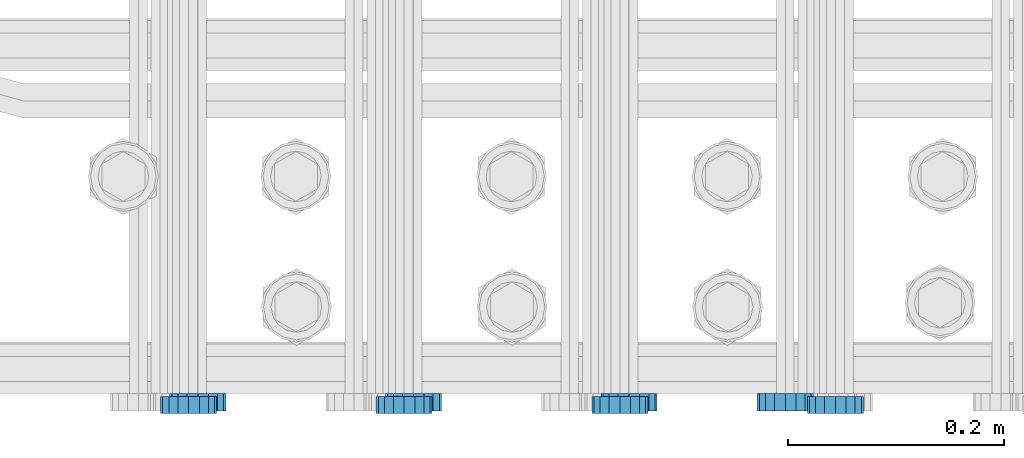
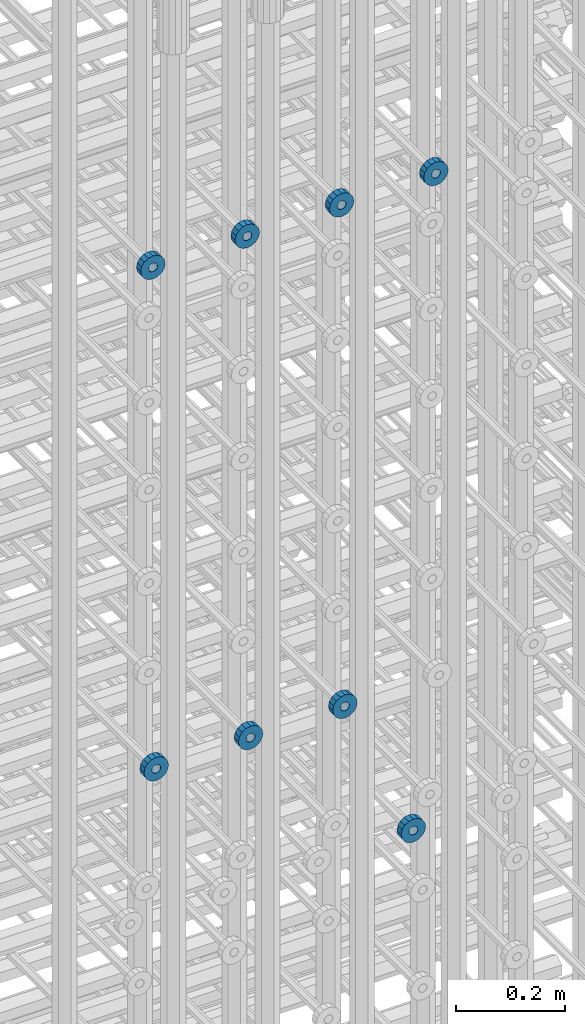
# One storey, part 115 of 177: 8 beams.
"""IFC2X3 building model written with IfcOpenShell, lengths in millimetres."""

from ifc_helpers import new_model, si_unit, frame, origin_with_axes, place, context, subcontext, project, spatial, faceted_brep, material, type_object, element, save


model = new_model("IFC2X3")

# Units and contexts
model_context_1 = context("Model", 3, precision=1e-05, world=origin_with_axes())
model_context_2 = context("Model", 3, precision=1e-05, world=origin_with_axes())
body_context = subcontext(model_context_2, "Body", "Model", "MODEL_VIEW")
ifc_project = project(units=[si_unit("LENGTHUNIT", "METRE", prefix="MILLI"), si_unit("AREAUNIT", "SQUARE_METRE"), si_unit("VOLUMEUNIT", "CUBIC_METRE"), si_unit("MASSUNIT", "GRAM", prefix="KILO"), si_unit("TIMEUNIT", "SECOND"), si_unit("PLANEANGLEUNIT", "RADIAN"), si_unit("SOLIDANGLEUNIT", "STERADIAN"), si_unit("THERMODYNAMICTEMPERATUREUNIT", "DEGREE_CELSIUS"), si_unit("LUMINOUSINTENSITYUNIT", "LUMEN")], contexts=[model_context_1])

# Site, building, storey
site_placement = place(None, origin_with_axes())
site = spatial("IfcSite", under=ifc_project, at=site_placement, CompositionType="ELEMENT")
building_placement = place(site_placement, origin_with_axes())
building = spatial("IfcBuilding", under=site, at=building_placement, Name="Undefined", CompositionType="ELEMENT")
storey_placement = place(building_placement, origin_with_axes())
storey = spatial("IfcBuildingStorey", under=building, at=storey_placement, Name="Undefined", CompositionType="ELEMENT", Elevation=0.0)

# Beams
ifc_material = material(Name="STEEL/Steel_Undefined")
beam_type = type_object("IfcBeamType", PredefinedType="NOTDEFINED")
beam_1_placement = place(storey_placement, frame((2030544.49847313, 6205075.98588578, 21128.9868125737), z_axis=(0.0, 0.0, -1.0), x_axis=(0.0, -1.0, 0.0)))
element("IfcBeam", 1, at=beam_1_placement, inside=storey, type_object=beam_type, material=ifc_material, context=body_context, shape_type="Brep", body=[
    faceted_brep([(0.0, -9.5, 0.0), (0.0, -8.77685555908829, 3.63549260746731), (16.0, -8.77685555908829, 3.63549260746731), (16.0, -9.5, 0.0), (0.0, -6.71751442085952, 6.71751442127061), (16.0, -6.71751442085952, 6.71751442127061), (0.0, -3.63549260701984, 8.77685555885546), (16.0, -3.63549260701984, 8.77685555885546), (-2.02452244836415e-12, 0.0, 9.5), (16.0, 0.0, 9.5), (0.0, 3.63549260701984, 8.77685555885546), (16.0, 3.63549260701984, 8.77685555885546), (0.0, 6.71751442085952, 6.71751442127061), (16.0, 6.71751442085952, 6.71751442127061), (0.0, 8.77685555908829, 3.63549260746731), (16.0, 8.77685555908829, 3.63549260746731), (0.0, 9.5, 0.0), (16.0, 9.5, 0.0), (0.0, 8.77685555908829, -3.63549260746731), (16.0, 8.77685555908829, -3.63549260746731), (0.0, 6.71751442085952, -6.71751442127061), (16.0, 6.71751442085952, -6.71751442127061), (0.0, 3.63549260701984, -8.77685555885546), (16.0, 3.63549260701984, -8.77685555885546), (2.02452244836415e-12, -3.69149155687865e-15, -9.5), (16.0, 0.0, -9.5), (0.0, -3.63549260701984, -8.77685555885546), (16.0, -3.63549260701984, -8.77685555885546), (0.0, -6.71751442085952, -6.71751442127061), (16.0, -6.71751442085952, -6.71751442127061), (0.0, -8.77685555908829, -3.63549260746731), (16.0, -8.77685555908829, -3.63549260746731), (0.0, -26.0, 0.0), (0.0, -24.0208678450435, -9.94976924149159), (16.0, -24.0208678450435, -9.94976924149159), (16.0, -26.0, 0.0), (0.0, -18.3847763109952, -18.3847763108497), (16.0, -18.3847763109952, -18.3847763108497), (0.0, -9.94976924173534, -24.0208678452946), (16.0, -9.94976924173534, -24.0208678452946), (0.0, 0.0, -26.0), (16.0, 0.0, -26.0), (0.0, 9.94976924173534, -24.0208678452946), (16.0, 9.94976924173534, -24.0208678452946), (0.0, 18.3847763109952, -18.3847763108497), (16.0, 18.3847763109952, -18.3847763108497), (0.0, 24.0208678450435, -9.94976924149159), (16.0, 24.0208678450435, -9.94976924149159), (0.0, 26.0, 0.0), (16.0, 26.0, 0.0), (0.0, 24.0208678450435, 9.94976924149159), (16.0, 24.0208678450435, 9.94976924149159), (0.0, 18.3847763109952, 18.3847763108497), (16.0, 18.3847763109952, 18.3847763108497), (0.0, 9.94976924173534, 24.0208678452946), (16.0, 9.94976924173534, 24.0208678452946), (0.0, 0.0, 26.0), (16.0, 0.0, 26.0), (0.0, -9.94976924173534, 24.0208678452946), (16.0, -9.94976924173534, 24.0208678452946), (0.0, -18.3847763109952, 18.3847763108497), (16.0, -18.3847763109952, 18.3847763108497), (0.0, -24.0208678450435, 9.94976924149159), (16.0, -24.0208678450435, 9.94976924149159)], [[[0, 1, 2, 3]], [[1, 4, 5, 2]], [[4, 6, 7, 5]], [[6, 8, 9, 7]], [[8, 10, 11, 9]], [[10, 12, 13, 11]], [[12, 14, 15, 13]], [[14, 16, 17, 15]], [[16, 18, 19, 17]], [[18, 20, 21, 19]], [[20, 22, 23, 21]], [[22, 24, 25, 23]], [[24, 26, 27, 25]], [[26, 28, 29, 27]], [[28, 30, 31, 29]], [[30, 0, 3, 31]], [[32, 33, 34, 35]], [[33, 36, 37, 34]], [[36, 38, 39, 37]], [[38, 40, 41, 39]], [[40, 42, 43, 41]], [[42, 44, 45, 43]], [[44, 46, 47, 45]], [[46, 48, 49, 47]], [[48, 50, 51, 49]], [[50, 52, 53, 51]], [[52, 54, 55, 53]], [[54, 56, 57, 55]], [[56, 58, 59, 57]], [[58, 60, 61, 59]], [[60, 62, 63, 61]], [[62, 32, 35, 63]], [[37, 39, 41, 43, 45, 47, 49, 51, 53, 55, 57, 59, 61, 63, 35, 34], [5, 7, 9, 11, 13, 15, 17, 19, 21, 23, 25, 27, 29, 31, 3, 2]], [[62, 60, 58, 56, 54, 52, 50, 48, 46, 44, 42, 40, 38, 36, 33, 32], [30, 28, 26, 24, 22, 20, 18, 16, 14, 12, 10, 8, 6, 4, 1, 0]]]),
])
beam_2_placement = place(storey_placement, frame((2030344.49847313, 6205075.98588578, 21128.9868125737), z_axis=(0.0, 0.0, -1.0), x_axis=(0.0, -1.0, 0.0)))
element("IfcBeam", 2, at=beam_2_placement, inside=storey, type_object=beam_type, material=ifc_material, context=body_context, shape_type="Brep", body=[
    faceted_brep([(0.0, -9.5, 0.0), (0.0, -8.77685555908829, 3.63549260746731), (16.0, -8.77685555908829, 3.63549260746731), (16.0, -9.5, 0.0), (0.0, -6.71751442085952, 6.71751442127061), (16.0, -6.71751442085952, 6.71751442127061), (0.0, -3.63549260701984, 8.77685555885546), (16.0, -3.63549260701984, 8.77685555885546), (-2.02452244836415e-12, 0.0, 9.5), (16.0, 0.0, 9.5), (0.0, 3.63549260701984, 8.77685555885546), (16.0, 3.63549260701984, 8.77685555885546), (0.0, 6.71751442085952, 6.71751442127061), (16.0, 6.71751442085952, 6.71751442127061), (0.0, 8.77685555908829, 3.63549260746731), (16.0, 8.77685555908829, 3.63549260746731), (0.0, 9.5, 0.0), (16.0, 9.5, 0.0), (0.0, 8.77685555908829, -3.63549260746731), (16.0, 8.77685555908829, -3.63549260746731), (0.0, 6.71751442085952, -6.71751442127061), (16.0, 6.71751442085952, -6.71751442127061), (0.0, 3.63549260701984, -8.77685555885546), (16.0, 3.63549260701984, -8.77685555885546), (2.02452244836415e-12, -3.69149155687865e-15, -9.5), (16.0, 0.0, -9.5), (0.0, -3.63549260701984, -8.77685555885546), (16.0, -3.63549260701984, -8.77685555885546), (0.0, -6.71751442085952, -6.71751442127061), (16.0, -6.71751442085952, -6.71751442127061), (0.0, -8.77685555908829, -3.63549260746731), (16.0, -8.77685555908829, -3.63549260746731), (0.0, -26.0, 0.0), (0.0, -24.0208678450435, -9.94976924149159), (16.0, -24.0208678450435, -9.94976924149159), (16.0, -26.0, 0.0), (0.0, -18.3847763109952, -18.3847763108497), (16.0, -18.3847763109952, -18.3847763108497), (0.0, -9.94976924173534, -24.0208678452946), (16.0, -9.94976924173534, -24.0208678452946), (0.0, 0.0, -26.0), (16.0, 0.0, -26.0), (0.0, 9.94976924173534, -24.0208678452946), (16.0, 9.94976924173534, -24.0208678452946), (0.0, 18.3847763109952, -18.3847763108497), (16.0, 18.3847763109952, -18.3847763108497), (0.0, 24.0208678450435, -9.94976924149159), (16.0, 24.0208678450435, -9.94976924149159), (0.0, 26.0, 0.0), (16.0, 26.0, 0.0), (0.0, 24.0208678450435, 9.94976924149159), (16.0, 24.0208678450435, 9.94976924149159), (0.0, 18.3847763109952, 18.3847763108497), (16.0, 18.3847763109952, 18.3847763108497), (0.0, 9.94976924173534, 24.0208678452946), (16.0, 9.94976924173534, 24.0208678452946), (0.0, 0.0, 26.0), (16.0, 0.0, 26.0), (0.0, -9.94976924173534, 24.0208678452946), (16.0, -9.94976924173534, 24.0208678452946), (0.0, -18.3847763109952, 18.3847763108497), (16.0, -18.3847763109952, 18.3847763108497), (0.0, -24.0208678450435, 9.94976924149159), (16.0, -24.0208678450435, 9.94976924149159)], [[[0, 1, 2, 3]], [[1, 4, 5, 2]], [[4, 6, 7, 5]], [[6, 8, 9, 7]], [[8, 10, 11, 9]], [[10, 12, 13, 11]], [[12, 14, 15, 13]], [[14, 16, 17, 15]], [[16, 18, 19, 17]], [[18, 20, 21, 19]], [[20, 22, 23, 21]], [[22, 24, 25, 23]], [[24, 26, 27, 25]], [[26, 28, 29, 27]], [[28, 30, 31, 29]], [[30, 0, 3, 31]], [[32, 33, 34, 35]], [[33, 36, 37, 34]], [[36, 38, 39, 37]], [[38, 40, 41, 39]], [[40, 42, 43, 41]], [[42, 44, 45, 43]], [[44, 46, 47, 45]], [[46, 48, 49, 47]], [[48, 50, 51, 49]], [[50, 52, 53, 51]], [[52, 54, 55, 53]], [[54, 56, 57, 55]], [[56, 58, 59, 57]], [[58, 60, 61, 59]], [[60, 62, 63, 61]], [[62, 32, 35, 63]], [[37, 39, 41, 43, 45, 47, 49, 51, 53, 55, 57, 59, 61, 63, 35, 34], [5, 7, 9, 11, 13, 15, 17, 19, 21, 23, 25, 27, 29, 31, 3, 2]], [[62, 60, 58, 56, 54, 52, 50, 48, 46, 44, 42, 40, 38, 36, 33, 32], [30, 28, 26, 24, 22, 20, 18, 16, 14, 12, 10, 8, 6, 4, 1, 0]]]),
])
beam_3_placement = place(storey_placement, frame((2030144.49847313, 6205075.98588578, 21128.9868125737), z_axis=(0.0, 0.0, -1.0), x_axis=(0.0, -1.0, 0.0)))
element("IfcBeam", 3, at=beam_3_placement, inside=storey, type_object=beam_type, material=ifc_material, context=body_context, shape_type="Brep", body=[
    faceted_brep([(0.0, -9.5, 0.0), (0.0, -8.77685555908829, 3.63549260746731), (16.0, -8.77685555908829, 3.63549260746731), (16.0, -9.5, 0.0), (0.0, -6.71751442085952, 6.71751442127061), (16.0, -6.71751442085952, 6.71751442127061), (0.0, -3.63549260701984, 8.77685555885546), (16.0, -3.63549260701984, 8.77685555885546), (-2.02452244836415e-12, 0.0, 9.5), (16.0, 0.0, 9.5), (0.0, 3.63549260701984, 8.77685555885546), (16.0, 3.63549260701984, 8.77685555885546), (0.0, 6.71751442085952, 6.71751442127061), (16.0, 6.71751442085952, 6.71751442127061), (0.0, 8.77685555908829, 3.63549260746731), (16.0, 8.77685555908829, 3.63549260746731), (0.0, 9.5, 0.0), (16.0, 9.5, 0.0), (0.0, 8.77685555908829, -3.63549260746731), (16.0, 8.77685555908829, -3.63549260746731), (0.0, 6.71751442085952, -6.71751442127061), (16.0, 6.71751442085952, -6.71751442127061), (0.0, 3.63549260701984, -8.77685555885546), (16.0, 3.63549260701984, -8.77685555885546), (2.02452244836415e-12, -3.69149155687865e-15, -9.5), (16.0, 0.0, -9.5), (0.0, -3.63549260701984, -8.77685555885546), (16.0, -3.63549260701984, -8.77685555885546), (0.0, -6.71751442085952, -6.71751442127061), (16.0, -6.71751442085952, -6.71751442127061), (0.0, -8.77685555908829, -3.63549260746731), (16.0, -8.77685555908829, -3.63549260746731), (0.0, -26.0, 0.0), (0.0, -24.0208678450435, -9.94976924149159), (16.0, -24.0208678450435, -9.94976924149159), (16.0, -26.0, 0.0), (0.0, -18.3847763109952, -18.3847763108497), (16.0, -18.3847763109952, -18.3847763108497), (0.0, -9.94976924173534, -24.0208678452946), (16.0, -9.94976924173534, -24.0208678452946), (0.0, 0.0, -26.0), (16.0, 0.0, -26.0), (0.0, 9.94976924173534, -24.0208678452946), (16.0, 9.94976924173534, -24.0208678452946), (0.0, 18.3847763109952, -18.3847763108497), (16.0, 18.3847763109952, -18.3847763108497), (0.0, 24.0208678450435, -9.94976924149159), (16.0, 24.0208678450435, -9.94976924149159), (0.0, 26.0, 0.0), (16.0, 26.0, 0.0), (0.0, 24.0208678450435, 9.94976924149159), (16.0, 24.0208678450435, 9.94976924149159), (0.0, 18.3847763109952, 18.3847763108497), (16.0, 18.3847763109952, 18.3847763108497), (0.0, 9.94976924173534, 24.0208678452946), (16.0, 9.94976924173534, 24.0208678452946), (0.0, 0.0, 26.0), (16.0, 0.0, 26.0), (0.0, -9.94976924173534, 24.0208678452946), (16.0, -9.94976924173534, 24.0208678452946), (0.0, -18.3847763109952, 18.3847763108497), (16.0, -18.3847763109952, 18.3847763108497), (0.0, -24.0208678450435, 9.94976924149159), (16.0, -24.0208678450435, 9.94976924149159)], [[[0, 1, 2, 3]], [[1, 4, 5, 2]], [[4, 6, 7, 5]], [[6, 8, 9, 7]], [[8, 10, 11, 9]], [[10, 12, 13, 11]], [[12, 14, 15, 13]], [[14, 16, 17, 15]], [[16, 18, 19, 17]], [[18, 20, 21, 19]], [[20, 22, 23, 21]], [[22, 24, 25, 23]], [[24, 26, 27, 25]], [[26, 28, 29, 27]], [[28, 30, 31, 29]], [[30, 0, 3, 31]], [[32, 33, 34, 35]], [[33, 36, 37, 34]], [[36, 38, 39, 37]], [[38, 40, 41, 39]], [[40, 42, 43, 41]], [[42, 44, 45, 43]], [[44, 46, 47, 45]], [[46, 48, 49, 47]], [[48, 50, 51, 49]], [[50, 52, 53, 51]], [[52, 54, 55, 53]], [[54, 56, 57, 55]], [[56, 58, 59, 57]], [[58, 60, 61, 59]], [[60, 62, 63, 61]], [[62, 32, 35, 63]], [[37, 39, 41, 43, 45, 47, 49, 51, 53, 55, 57, 59, 61, 63, 35, 34], [5, 7, 9, 11, 13, 15, 17, 19, 21, 23, 25, 27, 29, 31, 3, 2]], [[62, 60, 58, 56, 54, 52, 50, 48, 46, 44, 42, 40, 38, 36, 33, 32], [30, 28, 26, 24, 22, 20, 18, 16, 14, 12, 10, 8, 6, 4, 1, 0]]]),
])
beam_4_placement = place(storey_placement, frame((2030735.99847313, 6205073.48588765, 22257.486811804), z_axis=(0.0, 0.0, -1.0), x_axis=(0.0, -1.0, 0.0)))
element("IfcBeam", 4, at=beam_4_placement, inside=storey, type_object=beam_type, material=ifc_material, context=body_context, shape_type="Brep", body=[
    faceted_brep([(0.0, -9.5, 0.0), (0.0, -8.77685555908829, 3.63549260746731), (16.0, -8.77685555908829, 3.63549260746731), (16.0, -9.5, 0.0), (0.0, -6.71751442085952, 6.71751442127061), (16.0, -6.71751442085952, 6.71751442127061), (0.0, -3.63549260701984, 8.77685555885546), (16.0, -3.63549260701984, 8.77685555885546), (-2.02452244836415e-12, 0.0, 9.5), (16.0, 0.0, 9.5), (0.0, 3.63549260701984, 8.77685555885546), (16.0, 3.63549260701984, 8.77685555885546), (0.0, 6.71751442085952, 6.71751442127061), (16.0, 6.71751442085952, 6.71751442127061), (0.0, 8.77685555908829, 3.63549260746731), (16.0, 8.77685555908829, 3.63549260746731), (0.0, 9.5, 0.0), (16.0, 9.5, 0.0), (0.0, 8.77685555908829, -3.63549260746731), (16.0, 8.77685555908829, -3.63549260746731), (0.0, 6.71751442085952, -6.71751442127061), (16.0, 6.71751442085952, -6.71751442127061), (0.0, 3.63549260701984, -8.77685555885546), (16.0, 3.63549260701984, -8.77685555885546), (2.02452244836415e-12, -3.69149155687865e-15, -9.5), (16.0, 0.0, -9.5), (0.0, -3.63549260701984, -8.77685555885546), (16.0, -3.63549260701984, -8.77685555885546), (0.0, -6.71751442085952, -6.71751442127061), (16.0, -6.71751442085952, -6.71751442127061), (0.0, -8.77685555908829, -3.63549260746731), (16.0, -8.77685555908829, -3.63549260746731), (0.0, -26.0, 0.0), (0.0, -24.0208678450435, -9.94976924149159), (16.0, -24.0208678450435, -9.94976924149159), (16.0, -26.0, 0.0), (0.0, -18.3847763109952, -18.3847763108497), (16.0, -18.3847763109952, -18.3847763108497), (0.0, -9.94976924173534, -24.0208678452946), (16.0, -9.94976924173534, -24.0208678452946), (0.0, 0.0, -26.0), (16.0, 0.0, -26.0), (0.0, 9.94976924173534, -24.0208678452946), (16.0, 9.94976924173534, -24.0208678452946), (0.0, 18.3847763109952, -18.3847763108497), (16.0, 18.3847763109952, -18.3847763108497), (0.0, 24.0208678450435, -9.94976924149159), (16.0, 24.0208678450435, -9.94976924149159), (0.0, 26.0, 0.0), (16.0, 26.0, 0.0), (0.0, 24.0208678450435, 9.94976924149159), (16.0, 24.0208678450435, 9.94976924149159), (0.0, 18.3847763109952, 18.3847763108497), (16.0, 18.3847763109952, 18.3847763108497), (0.0, 9.94976924173534, 24.0208678452946), (16.0, 9.94976924173534, 24.0208678452946), (0.0, 0.0, 26.0), (16.0, 0.0, 26.0), (0.0, -9.94976924173534, 24.0208678452946), (16.0, -9.94976924173534, 24.0208678452946), (0.0, -18.3847763109952, 18.3847763108497), (16.0, -18.3847763109952, 18.3847763108497), (0.0, -24.0208678450435, 9.94976924149159), (16.0, -24.0208678450435, 9.94976924149159)], [[[0, 1, 2, 3]], [[1, 4, 5, 2]], [[4, 6, 7, 5]], [[6, 8, 9, 7]], [[8, 10, 11, 9]], [[10, 12, 13, 11]], [[12, 14, 15, 13]], [[14, 16, 17, 15]], [[16, 18, 19, 17]], [[18, 20, 21, 19]], [[20, 22, 23, 21]], [[22, 24, 25, 23]], [[24, 26, 27, 25]], [[26, 28, 29, 27]], [[28, 30, 31, 29]], [[30, 0, 3, 31]], [[32, 33, 34, 35]], [[33, 36, 37, 34]], [[36, 38, 39, 37]], [[38, 40, 41, 39]], [[40, 42, 43, 41]], [[42, 44, 45, 43]], [[44, 46, 47, 45]], [[46, 48, 49, 47]], [[48, 50, 51, 49]], [[50, 52, 53, 51]], [[52, 54, 55, 53]], [[54, 56, 57, 55]], [[56, 58, 59, 57]], [[58, 60, 61, 59]], [[60, 62, 63, 61]], [[62, 32, 35, 63]], [[37, 39, 41, 43, 45, 47, 49, 51, 53, 55, 57, 59, 61, 63, 35, 34], [5, 7, 9, 11, 13, 15, 17, 19, 21, 23, 25, 27, 29, 31, 3, 2]], [[62, 60, 58, 56, 54, 52, 50, 48, 46, 44, 42, 40, 38, 36, 33, 32], [30, 28, 26, 24, 22, 20, 18, 16, 14, 12, 10, 8, 6, 4, 1, 0]]]),
])
beam_5_placement = place(storey_placement, frame((2030535.99847313, 6205073.48588765, 22257.486811804), z_axis=(0.0, 0.0, -1.0), x_axis=(0.0, -1.0, 0.0)))
element("IfcBeam", 5, at=beam_5_placement, inside=storey, type_object=beam_type, material=ifc_material, context=body_context, shape_type="Brep", body=[
    faceted_brep([(0.0, -9.5, 0.0), (0.0, -8.77685555908829, 3.63549260746731), (16.0, -8.77685555908829, 3.63549260746731), (16.0, -9.5, 0.0), (0.0, -6.71751442085952, 6.71751442127061), (16.0, -6.71751442085952, 6.71751442127061), (0.0, -3.63549260701984, 8.77685555885546), (16.0, -3.63549260701984, 8.77685555885546), (-2.02452244836415e-12, 0.0, 9.5), (16.0, 0.0, 9.5), (0.0, 3.63549260701984, 8.77685555885546), (16.0, 3.63549260701984, 8.77685555885546), (0.0, 6.71751442085952, 6.71751442127061), (16.0, 6.71751442085952, 6.71751442127061), (0.0, 8.77685555908829, 3.63549260746731), (16.0, 8.77685555908829, 3.63549260746731), (0.0, 9.5, 0.0), (16.0, 9.5, 0.0), (0.0, 8.77685555908829, -3.63549260746731), (16.0, 8.77685555908829, -3.63549260746731), (0.0, 6.71751442085952, -6.71751442127061), (16.0, 6.71751442085952, -6.71751442127061), (0.0, 3.63549260701984, -8.77685555885546), (16.0, 3.63549260701984, -8.77685555885546), (2.02452244836415e-12, -3.69149155687865e-15, -9.5), (16.0, 0.0, -9.5), (0.0, -3.63549260701984, -8.77685555885546), (16.0, -3.63549260701984, -8.77685555885546), (0.0, -6.71751442085952, -6.71751442127061), (16.0, -6.71751442085952, -6.71751442127061), (0.0, -8.77685555908829, -3.63549260746731), (16.0, -8.77685555908829, -3.63549260746731), (0.0, -26.0, 0.0), (0.0, -24.0208678450435, -9.94976924149159), (16.0, -24.0208678450435, -9.94976924149159), (16.0, -26.0, 0.0), (0.0, -18.3847763109952, -18.3847763108497), (16.0, -18.3847763109952, -18.3847763108497), (0.0, -9.94976924173534, -24.0208678452946), (16.0, -9.94976924173534, -24.0208678452946), (0.0, 0.0, -26.0), (16.0, 0.0, -26.0), (0.0, 9.94976924173534, -24.0208678452946), (16.0, 9.94976924173534, -24.0208678452946), (0.0, 18.3847763109952, -18.3847763108497), (16.0, 18.3847763109952, -18.3847763108497), (0.0, 24.0208678450435, -9.94976924149159), (16.0, 24.0208678450435, -9.94976924149159), (0.0, 26.0, 0.0), (16.0, 26.0, 0.0), (0.0, 24.0208678450435, 9.94976924149159), (16.0, 24.0208678450435, 9.94976924149159), (0.0, 18.3847763109952, 18.3847763108497), (16.0, 18.3847763109952, 18.3847763108497), (0.0, 9.94976924173534, 24.0208678452946), (16.0, 9.94976924173534, 24.0208678452946), (0.0, 0.0, 26.0), (16.0, 0.0, 26.0), (0.0, -9.94976924173534, 24.0208678452946), (16.0, -9.94976924173534, 24.0208678452946), (0.0, -18.3847763109952, 18.3847763108497), (16.0, -18.3847763109952, 18.3847763108497), (0.0, -24.0208678450435, 9.94976924149159), (16.0, -24.0208678450435, 9.94976924149159)], [[[0, 1, 2, 3]], [[1, 4, 5, 2]], [[4, 6, 7, 5]], [[6, 8, 9, 7]], [[8, 10, 11, 9]], [[10, 12, 13, 11]], [[12, 14, 15, 13]], [[14, 16, 17, 15]], [[16, 18, 19, 17]], [[18, 20, 21, 19]], [[20, 22, 23, 21]], [[22, 24, 25, 23]], [[24, 26, 27, 25]], [[26, 28, 29, 27]], [[28, 30, 31, 29]], [[30, 0, 3, 31]], [[32, 33, 34, 35]], [[33, 36, 37, 34]], [[36, 38, 39, 37]], [[38, 40, 41, 39]], [[40, 42, 43, 41]], [[42, 44, 45, 43]], [[44, 46, 47, 45]], [[46, 48, 49, 47]], [[48, 50, 51, 49]], [[50, 52, 53, 51]], [[52, 54, 55, 53]], [[54, 56, 57, 55]], [[56, 58, 59, 57]], [[58, 60, 61, 59]], [[60, 62, 63, 61]], [[62, 32, 35, 63]], [[37, 39, 41, 43, 45, 47, 49, 51, 53, 55, 57, 59, 61, 63, 35, 34], [5, 7, 9, 11, 13, 15, 17, 19, 21, 23, 25, 27, 29, 31, 3, 2]], [[62, 60, 58, 56, 54, 52, 50, 48, 46, 44, 42, 40, 38, 36, 33, 32], [30, 28, 26, 24, 22, 20, 18, 16, 14, 12, 10, 8, 6, 4, 1, 0]]]),
])
beam_6_placement = place(storey_placement, frame((2030335.99847313, 6205073.48588765, 22257.486811804), z_axis=(0.0, 0.0, -1.0), x_axis=(0.0, -1.0, 0.0)))
element("IfcBeam", 6, at=beam_6_placement, inside=storey, type_object=beam_type, material=ifc_material, context=body_context, shape_type="Brep", body=[
    faceted_brep([(0.0, -9.5, 0.0), (0.0, -8.77685555908829, 3.63549260746731), (16.0, -8.77685555908829, 3.63549260746731), (16.0, -9.5, 0.0), (0.0, -6.71751442085952, 6.71751442127061), (16.0, -6.71751442085952, 6.71751442127061), (0.0, -3.63549260701984, 8.77685555885546), (16.0, -3.63549260701984, 8.77685555885546), (-2.02452244836415e-12, 0.0, 9.5), (16.0, 0.0, 9.5), (0.0, 3.63549260701984, 8.77685555885546), (16.0, 3.63549260701984, 8.77685555885546), (0.0, 6.71751442085952, 6.71751442127061), (16.0, 6.71751442085952, 6.71751442127061), (0.0, 8.77685555908829, 3.63549260746731), (16.0, 8.77685555908829, 3.63549260746731), (0.0, 9.5, 0.0), (16.0, 9.5, 0.0), (0.0, 8.77685555908829, -3.63549260746731), (16.0, 8.77685555908829, -3.63549260746731), (0.0, 6.71751442085952, -6.71751442127061), (16.0, 6.71751442085952, -6.71751442127061), (0.0, 3.63549260701984, -8.77685555885546), (16.0, 3.63549260701984, -8.77685555885546), (2.02452244836415e-12, -3.69149155687865e-15, -9.5), (16.0, 0.0, -9.5), (0.0, -3.63549260701984, -8.77685555885546), (16.0, -3.63549260701984, -8.77685555885546), (0.0, -6.71751442085952, -6.71751442127061), (16.0, -6.71751442085952, -6.71751442127061), (0.0, -8.77685555908829, -3.63549260746731), (16.0, -8.77685555908829, -3.63549260746731), (0.0, -26.0, 0.0), (0.0, -24.0208678450435, -9.94976924149159), (16.0, -24.0208678450435, -9.94976924149159), (16.0, -26.0, 0.0), (0.0, -18.3847763109952, -18.3847763108497), (16.0, -18.3847763109952, -18.3847763108497), (0.0, -9.94976924173534, -24.0208678452946), (16.0, -9.94976924173534, -24.0208678452946), (0.0, 0.0, -26.0), (16.0, 0.0, -26.0), (0.0, 9.94976924173534, -24.0208678452946), (16.0, 9.94976924173534, -24.0208678452946), (0.0, 18.3847763109952, -18.3847763108497), (16.0, 18.3847763109952, -18.3847763108497), (0.0, 24.0208678450435, -9.94976924149159), (16.0, 24.0208678450435, -9.94976924149159), (0.0, 26.0, 0.0), (16.0, 26.0, 0.0), (0.0, 24.0208678450435, 9.94976924149159), (16.0, 24.0208678450435, 9.94976924149159), (0.0, 18.3847763109952, 18.3847763108497), (16.0, 18.3847763109952, 18.3847763108497), (0.0, 9.94976924173534, 24.0208678452946), (16.0, 9.94976924173534, 24.0208678452946), (0.0, 0.0, 26.0), (16.0, 0.0, 26.0), (0.0, -9.94976924173534, 24.0208678452946), (16.0, -9.94976924173534, 24.0208678452946), (0.0, -18.3847763109952, 18.3847763108497), (16.0, -18.3847763109952, 18.3847763108497), (0.0, -24.0208678450435, 9.94976924149159), (16.0, -24.0208678450435, 9.94976924149159)], [[[0, 1, 2, 3]], [[1, 4, 5, 2]], [[4, 6, 7, 5]], [[6, 8, 9, 7]], [[8, 10, 11, 9]], [[10, 12, 13, 11]], [[12, 14, 15, 13]], [[14, 16, 17, 15]], [[16, 18, 19, 17]], [[18, 20, 21, 19]], [[20, 22, 23, 21]], [[22, 24, 25, 23]], [[24, 26, 27, 25]], [[26, 28, 29, 27]], [[28, 30, 31, 29]], [[30, 0, 3, 31]], [[32, 33, 34, 35]], [[33, 36, 37, 34]], [[36, 38, 39, 37]], [[38, 40, 41, 39]], [[40, 42, 43, 41]], [[42, 44, 45, 43]], [[44, 46, 47, 45]], [[46, 48, 49, 47]], [[48, 50, 51, 49]], [[50, 52, 53, 51]], [[52, 54, 55, 53]], [[54, 56, 57, 55]], [[56, 58, 59, 57]], [[58, 60, 61, 59]], [[60, 62, 63, 61]], [[62, 32, 35, 63]], [[37, 39, 41, 43, 45, 47, 49, 51, 53, 55, 57, 59, 61, 63, 35, 34], [5, 7, 9, 11, 13, 15, 17, 19, 21, 23, 25, 27, 29, 31, 3, 2]], [[62, 60, 58, 56, 54, 52, 50, 48, 46, 44, 42, 40, 38, 36, 33, 32], [30, 28, 26, 24, 22, 20, 18, 16, 14, 12, 10, 8, 6, 4, 1, 0]]]),
])
beam_7_placement = place(storey_placement, frame((2030135.99847313, 6205073.48588765, 22257.4868118041), z_axis=(0.0, 0.0, -1.0), x_axis=(0.0, -1.0, 0.0)))
element("IfcBeam", 7, at=beam_7_placement, inside=storey, type_object=beam_type, material=ifc_material, context=body_context, shape_type="Brep", body=[
    faceted_brep([(0.0, -9.5, 0.0), (0.0, -8.77685555908829, 3.63549260746731), (16.0, -8.77685555908829, 3.63549260746731), (16.0, -9.5, 0.0), (0.0, -6.71751442085952, 6.71751442127061), (16.0, -6.71751442085952, 6.71751442127061), (0.0, -3.63549260701984, 8.77685555885546), (16.0, -3.63549260701984, 8.77685555885546), (-2.02452244836415e-12, 0.0, 9.5), (16.0, 0.0, 9.5), (0.0, 3.63549260701984, 8.77685555885546), (16.0, 3.63549260701984, 8.77685555885546), (0.0, 6.71751442085952, 6.71751442127061), (16.0, 6.71751442085952, 6.71751442127061), (0.0, 8.77685555908829, 3.63549260746731), (16.0, 8.77685555908829, 3.63549260746731), (0.0, 9.5, 0.0), (16.0, 9.5, 0.0), (0.0, 8.77685555908829, -3.63549260746731), (16.0, 8.77685555908829, -3.63549260746731), (0.0, 6.71751442085952, -6.71751442127061), (16.0, 6.71751442085952, -6.71751442127061), (0.0, 3.63549260701984, -8.77685555885546), (16.0, 3.63549260701984, -8.77685555885546), (2.02452244836415e-12, -3.69149155687865e-15, -9.5), (16.0, 0.0, -9.5), (0.0, -3.63549260701984, -8.77685555885546), (16.0, -3.63549260701984, -8.77685555885546), (0.0, -6.71751442085952, -6.71751442127061), (16.0, -6.71751442085952, -6.71751442127061), (0.0, -8.77685555908829, -3.63549260746731), (16.0, -8.77685555908829, -3.63549260746731), (0.0, -26.0, 0.0), (0.0, -24.0208678450435, -9.94976924149159), (16.0, -24.0208678450435, -9.94976924149159), (16.0, -26.0, 0.0), (0.0, -18.3847763109952, -18.3847763108497), (16.0, -18.3847763109952, -18.3847763108497), (0.0, -9.94976924173534, -24.0208678452946), (16.0, -9.94976924173534, -24.0208678452946), (0.0, 0.0, -26.0), (16.0, 0.0, -26.0), (0.0, 9.94976924173534, -24.0208678452946), (16.0, 9.94976924173534, -24.0208678452946), (0.0, 18.3847763109952, -18.3847763108497), (16.0, 18.3847763109952, -18.3847763108497), (0.0, 24.0208678450435, -9.94976924149159), (16.0, 24.0208678450435, -9.94976924149159), (0.0, 26.0, 0.0), (16.0, 26.0, 0.0), (0.0, 24.0208678450435, 9.94976924149159), (16.0, 24.0208678450435, 9.94976924149159), (0.0, 18.3847763109952, 18.3847763108497), (16.0, 18.3847763109952, 18.3847763108497), (0.0, 9.94976924173534, 24.0208678452946), (16.0, 9.94976924173534, 24.0208678452946), (0.0, 0.0, 26.0), (16.0, 0.0, 26.0), (0.0, -9.94976924173534, 24.0208678452946), (16.0, -9.94976924173534, 24.0208678452946), (0.0, -18.3847763109952, 18.3847763108497), (16.0, -18.3847763109952, 18.3847763108497), (0.0, -24.0208678450435, 9.94976924149159), (16.0, -24.0208678450435, 9.94976924149159)], [[[0, 1, 2, 3]], [[1, 4, 5, 2]], [[4, 6, 7, 5]], [[6, 8, 9, 7]], [[8, 10, 11, 9]], [[10, 12, 13, 11]], [[12, 14, 15, 13]], [[14, 16, 17, 15]], [[16, 18, 19, 17]], [[18, 20, 21, 19]], [[20, 22, 23, 21]], [[22, 24, 25, 23]], [[24, 26, 27, 25]], [[26, 28, 29, 27]], [[28, 30, 31, 29]], [[30, 0, 3, 31]], [[32, 33, 34, 35]], [[33, 36, 37, 34]], [[36, 38, 39, 37]], [[38, 40, 41, 39]], [[40, 42, 43, 41]], [[42, 44, 45, 43]], [[44, 46, 47, 45]], [[46, 48, 49, 47]], [[48, 50, 51, 49]], [[50, 52, 53, 51]], [[52, 54, 55, 53]], [[54, 56, 57, 55]], [[56, 58, 59, 57]], [[58, 60, 61, 59]], [[60, 62, 63, 61]], [[62, 32, 35, 63]], [[37, 39, 41, 43, 45, 47, 49, 51, 53, 55, 57, 59, 61, 63, 35, 34], [5, 7, 9, 11, 13, 15, 17, 19, 21, 23, 25, 27, 29, 31, 3, 2]], [[62, 60, 58, 56, 54, 52, 50, 48, 46, 44, 42, 40, 38, 36, 33, 32], [30, 28, 26, 24, 22, 20, 18, 16, 14, 12, 10, 8, 6, 4, 1, 0]]]),
])
beam_8_placement = place(storey_placement, frame((2030689.49847313, 6205075.98588033, 20799.986811442), z_axis=(0.0, 0.0, -1.0), x_axis=(0.0, -1.0, 0.0)))
element("IfcBeam", 8, at=beam_8_placement, inside=storey, type_object=beam_type, material=ifc_material, context=body_context, shape_type="Brep", body=[
    faceted_brep([(0.0, -9.5, 0.0), (0.0, -8.77685555908829, 3.63549260746731), (16.0, -8.77685555908829, 3.63549260746731), (16.0, -9.5, 0.0), (0.0, -6.71751442085952, 6.71751442127061), (16.0, -6.71751442085952, 6.71751442127061), (0.0, -3.63549260701984, 8.77685555885546), (16.0, -3.63549260701984, 8.77685555885546), (-2.02452244836415e-12, 0.0, 9.5), (16.0, 0.0, 9.5), (0.0, 3.63549260701984, 8.77685555885546), (16.0, 3.63549260701984, 8.77685555885546), (0.0, 6.71751442085952, 6.71751442127061), (16.0, 6.71751442085952, 6.71751442127061), (0.0, 8.77685555908829, 3.63549260746731), (16.0, 8.77685555908829, 3.63549260746731), (0.0, 9.5, 0.0), (16.0, 9.5, 0.0), (0.0, 8.77685555908829, -3.63549260746731), (16.0, 8.77685555908829, -3.63549260746731), (0.0, 6.71751442085952, -6.71751442127061), (16.0, 6.71751442085952, -6.71751442127061), (0.0, 3.63549260701984, -8.77685555885546), (16.0, 3.63549260701984, -8.77685555885546), (2.02452244836415e-12, -3.69149155687865e-15, -9.5), (16.0, 0.0, -9.5), (0.0, -3.63549260701984, -8.77685555885546), (16.0, -3.63549260701984, -8.77685555885546), (0.0, -6.71751442085952, -6.71751442127061), (16.0, -6.71751442085952, -6.71751442127061), (0.0, -8.77685555908829, -3.63549260746731), (16.0, -8.77685555908829, -3.63549260746731), (0.0, -26.0, 0.0), (0.0, -24.0208678450435, -9.94976924149159), (16.0, -24.0208678450435, -9.94976924149159), (16.0, -26.0, 0.0), (0.0, -18.3847763109952, -18.3847763108497), (16.0, -18.3847763109952, -18.3847763108497), (0.0, -9.94976924173534, -24.0208678452946), (16.0, -9.94976924173534, -24.0208678452946), (0.0, 0.0, -26.0), (16.0, 0.0, -26.0), (0.0, 9.94976924173534, -24.0208678452946), (16.0, 9.94976924173534, -24.0208678452946), (0.0, 18.3847763109952, -18.3847763108497), (16.0, 18.3847763109952, -18.3847763108497), (0.0, 24.0208678450435, -9.94976924149159), (16.0, 24.0208678450435, -9.94976924149159), (0.0, 26.0, 0.0), (16.0, 26.0, 0.0), (0.0, 24.0208678450435, 9.94976924149159), (16.0, 24.0208678450435, 9.94976924149159), (0.0, 18.3847763109952, 18.3847763108497), (16.0, 18.3847763109952, 18.3847763108497), (0.0, 9.94976924173534, 24.0208678452946), (16.0, 9.94976924173534, 24.0208678452946), (0.0, 0.0, 26.0), (16.0, 0.0, 26.0), (0.0, -9.94976924173534, 24.0208678452946), (16.0, -9.94976924173534, 24.0208678452946), (0.0, -18.3847763109952, 18.3847763108497), (16.0, -18.3847763109952, 18.3847763108497), (0.0, -24.0208678450435, 9.94976924149159), (16.0, -24.0208678450435, 9.94976924149159)], [[[0, 1, 2, 3]], [[1, 4, 5, 2]], [[4, 6, 7, 5]], [[6, 8, 9, 7]], [[8, 10, 11, 9]], [[10, 12, 13, 11]], [[12, 14, 15, 13]], [[14, 16, 17, 15]], [[16, 18, 19, 17]], [[18, 20, 21, 19]], [[20, 22, 23, 21]], [[22, 24, 25, 23]], [[24, 26, 27, 25]], [[26, 28, 29, 27]], [[28, 30, 31, 29]], [[30, 0, 3, 31]], [[32, 33, 34, 35]], [[33, 36, 37, 34]], [[36, 38, 39, 37]], [[38, 40, 41, 39]], [[40, 42, 43, 41]], [[42, 44, 45, 43]], [[44, 46, 47, 45]], [[46, 48, 49, 47]], [[48, 50, 51, 49]], [[50, 52, 53, 51]], [[52, 54, 55, 53]], [[54, 56, 57, 55]], [[56, 58, 59, 57]], [[58, 60, 61, 59]], [[60, 62, 63, 61]], [[62, 32, 35, 63]], [[37, 39, 41, 43, 45, 47, 49, 51, 53, 55, 57, 59, 61, 63, 35, 34], [5, 7, 9, 11, 13, 15, 17, 19, 21, 23, 25, 27, 29, 31, 3, 2]], [[62, 60, 58, 56, 54, 52, 50, 48, 46, 44, 42, 40, 38, 36, 33, 32], [30, 28, 26, 24, 22, 20, 18, 16, 14, 12, 10, 8, 6, 4, 1, 0]]]),
])

save(model, "model.ifc")
